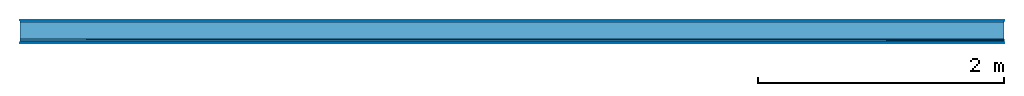
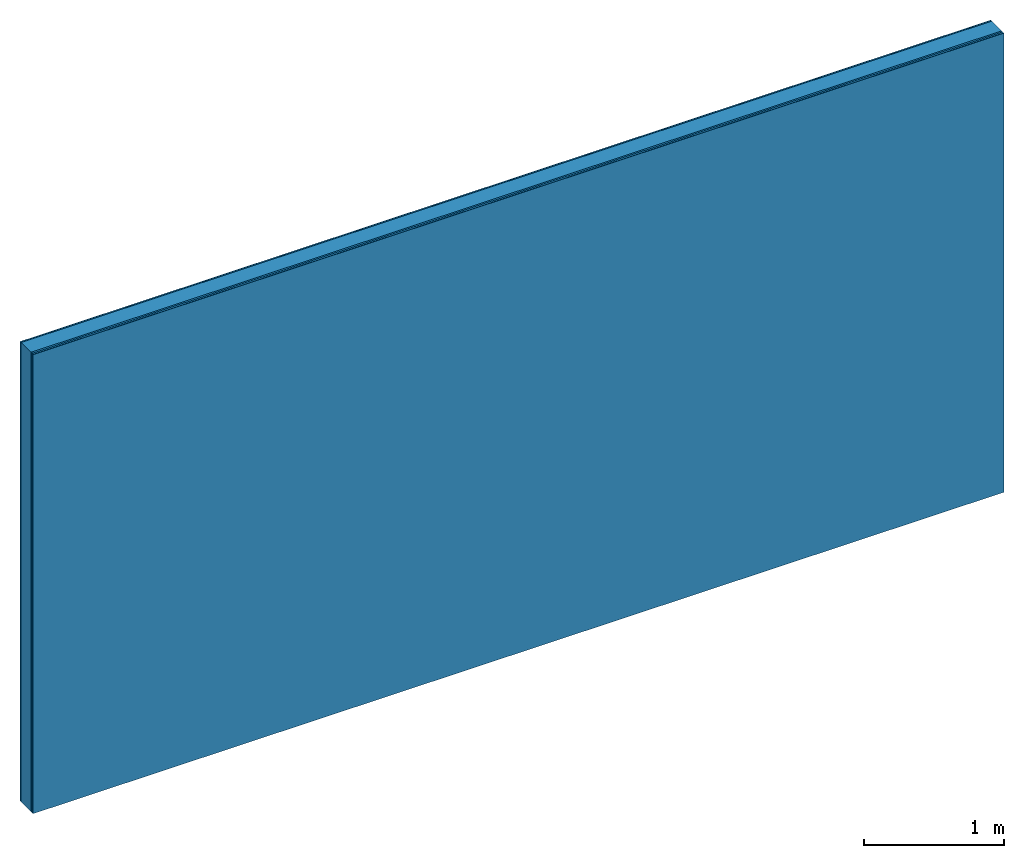
# One storey: 5 plates, 1 member, 1 element without a shape of its own.
"""IFC4 building model written with IfcOpenShell, lengths in metres."""

from ifc_helpers import new_model, si_unit, derived_unit, direction, frame, frame_2d, origin, origin_with_axes, place, context, project, spatial, rectangle, extrude, material, layer, layer_set, type_object, element, aggregate, save


model = new_model("IFC4")

# Units and contexts
plan_context = context("Plan", 3, precision=1e-05, world=origin(), true_north=direction((0.0, 1.0)))
model_context = context("Model", 3, precision=1e-05, world=origin(), true_north=direction((0.0, 1.0)))
ifc_project = project(units=[si_unit("LENGTHUNIT", "METRE"), derived_unit("SOUNDPRESSUREUNIT", [(si_unit("PRESSUREUNIT", "PASCAL", prefix="MICRO"), 0)]), si_unit("ENERGYUNIT", "JOULE", prefix="MEGA"), si_unit("MASSUNIT", "GRAM", prefix="KILO"), derived_unit("THERMALTRANSMITTANCEUNIT", [(si_unit("POWERUNIT", "WATT"), 1), (si_unit("AREAUNIT", "SQUARE_METRE"), -1), (si_unit("THERMODYNAMICTEMPERATUREUNIT", "KELVIN"), -1)]), derived_unit("AREADENSITYUNIT", [(si_unit("MASSUNIT", "GRAM", prefix="KILO"), 1), (si_unit("AREAUNIT", "SQUARE_METRE"), -1)]), derived_unit("USERDEFINED", [(si_unit("ENERGYUNIT", "JOULE", prefix="MEGA"), 1), (si_unit("AREAUNIT", "SQUARE_METRE"), -1)])], contexts=[plan_context, model_context])

# Site, building, storey
site = spatial("IfcSite", under=ifc_project)
building_placement = place(None, origin())
building = spatial("IfcBuilding", under=site, at=building_placement)
storey_placement = place(building_placement, origin())
storey = spatial("IfcBuildingStorey", under=building, at=storey_placement)

# Wall, member, plates
ifc_material_1 = material(Category="04.001")
ifc_layer_1 = layer(ifc_material_1, 0.003, Name="Surface")
ifc_material_2 = material(Name="Plasterboard type A", Category="03.008")
ifc_layer_2 = layer(ifc_material_2, 0.0125, Name="1st layer")
ifc_material_3 = material(Name="of the art")
ifc_layer_3 = layer(ifc_material_3, 0.0, Name="Bond")
ifc_layer_4 = layer(None, 0.14, Name="Support")
ifc_layer_5 = layer(ifc_material_3, 0.0, Name="Bond")
ifc_material_4 = material(Name="DFH2IR Knauf Diamant hard- plasterboard", Category="03.007")
ifc_layer_6 = layer(ifc_material_4, 0.015, Name="1st layer")
ifc_layer_7 = layer(ifc_material_4, 0.015, Name="2nd layer")
ifc_layer_8 = layer(ifc_material_1, 0.003, Name="Surface")
ifc_layer_set = layer_set([ifc_layer_1, ifc_layer_2, ifc_layer_3, ifc_layer_4, ifc_layer_5, ifc_layer_6, ifc_layer_7, ifc_layer_8])
wall_type = type_object("IfcWallType", Name="C0370", PredefinedType="NOTDEFINED", material=ifc_layer_set)
wall_placement = place(None, frame((0.0, 0.0, 0.0), z_axis=(0.0, -1.0, 0.0), x_axis=(1.0, 0.0, 0.0)))
wall = element("IfcWall", 1, at=wall_placement, inside=storey, type_object=wall_type, material=ifc_layer_set, Name="Wall #1")
ifc_material_5 = material(Name="Solid timber panel")
member_placement = place(wall_placement, origin())
member = element("IfcMember", 2, at=member_placement, material=ifc_material_5, Name="Support", context=plan_context, shape_type="SweptSolid", body=[
    extrude(rectangle(XDim=1.0, YDim=0.14, at=frame_2d((0.5, 0.07), x_axis=(1.0, 0.0))), frame((0.0, 4.0, 0.0155), z_axis=(0.0, -1.0, 0.0), x_axis=(1.0, 0.0, 0.0)), (0.0, 0.0, 1.0), 4.0),
    extrude(rectangle(XDim=1.0, YDim=0.14, at=frame_2d((0.5, 0.07), x_axis=(1.0, 0.0))), frame((1.0, 4.0, 0.0155), z_axis=(0.0, -1.0, 0.0), x_axis=(1.0, 0.0, 0.0)), (0.0, 0.0, 1.0), 4.0),
    extrude(rectangle(XDim=1.0, YDim=0.14, at=frame_2d((0.5, 0.07), x_axis=(1.0, 0.0))), frame((2.0, 4.0, 0.0155), z_axis=(0.0, -1.0, 0.0), x_axis=(1.0, 0.0, 0.0)), (0.0, 0.0, 1.0), 4.0),
    extrude(rectangle(XDim=1.0, YDim=0.14, at=frame_2d((0.5, 0.07), x_axis=(1.0, 0.0))), frame((3.0, 4.0, 0.0155), z_axis=(0.0, -1.0, 0.0), x_axis=(1.0, 0.0, 0.0)), (0.0, 0.0, 1.0), 4.0),
    extrude(rectangle(XDim=1.0, YDim=0.14, at=frame_2d((0.5, 0.07), x_axis=(1.0, 0.0))), frame((4.0, 4.0, 0.0155), z_axis=(0.0, -1.0, 0.0), x_axis=(1.0, 0.0, 0.0)), (0.0, 0.0, 1.0), 4.0),
    extrude(rectangle(XDim=1.0, YDim=0.14, at=frame_2d((0.5, 0.07), x_axis=(1.0, 0.0))), frame((5.0, 4.0, 0.0155), z_axis=(0.0, -1.0, 0.0), x_axis=(1.0, 0.0, 0.0)), (0.0, 0.0, 1.0), 4.0),
    extrude(rectangle(XDim=1.0, YDim=0.14, at=frame_2d((0.5, 0.07), x_axis=(1.0, 0.0))), frame((6.0, 4.0, 0.0155), z_axis=(0.0, -1.0, 0.0), x_axis=(1.0, 0.0, 0.0)), (0.0, 0.0, 1.0), 4.0),
    extrude(rectangle(XDim=1.0, YDim=0.14, at=frame_2d((0.5, 0.07), x_axis=(1.0, 0.0))), frame((7.0, 4.0, 0.0155), z_axis=(0.0, -1.0, 0.0), x_axis=(1.0, 0.0, 0.0)), (0.0, 0.0, 1.0), 4.0),
])
plate_1_placement = place(wall_placement, origin())
plate_1 = element("IfcPlate", 3, at=plate_1_placement, material=ifc_material_1, Name="Surface", context=plan_context, shape_type="SweptSolid", body=[
    extrude(rectangle(XDim=8.0, YDim=4.0, at=frame_2d((4.0, 2.0), x_axis=(1.0, 0.0))), origin_with_axes(), (0.0, 0.0, 1.0), 0.003),
])
plate_2_placement = place(wall_placement, origin())
plate_2 = element("IfcPlate", 4, at=plate_2_placement, material=ifc_material_2, Name="1st layer", context=plan_context, shape_type="SweptSolid", body=[
    extrude(rectangle(XDim=8.0, YDim=4.0, at=frame_2d((4.0, 2.0), x_axis=(1.0, 0.0))), frame((0.0, 0.0, 0.003), z_axis=(0.0, 0.0, 1.0), x_axis=(1.0, 0.0, 0.0)), (0.0, 0.0, 1.0), 0.0125),
])
plate_3_placement = place(wall_placement, origin())
plate_3 = element("IfcPlate", 5, at=plate_3_placement, material=ifc_material_4, Name="1st layer", context=plan_context, shape_type="SweptSolid", body=[
    extrude(rectangle(XDim=8.0, YDim=4.0, at=frame_2d((4.0, 2.0), x_axis=(1.0, 0.0))), frame((0.0, 0.0, 0.1555), z_axis=(0.0, 0.0, 1.0), x_axis=(1.0, 0.0, 0.0)), (0.0, 0.0, 1.0), 0.015),
])
plate_4_placement = place(wall_placement, origin())
plate_4 = element("IfcPlate", 6, at=plate_4_placement, material=ifc_material_4, Name="2nd layer", context=plan_context, shape_type="SweptSolid", body=[
    extrude(rectangle(XDim=8.0, YDim=4.0, at=frame_2d((4.0, 2.0), x_axis=(1.0, 0.0))), frame((0.0, 0.0, 0.1705), z_axis=(0.0, 0.0, 1.0), x_axis=(1.0, 0.0, 0.0)), (0.0, 0.0, 1.0), 0.015),
])
plate_5_placement = place(wall_placement, origin())
plate_5 = element("IfcPlate", 7, at=plate_5_placement, material=ifc_material_1, Name="Surface", context=plan_context, shape_type="SweptSolid", body=[
    extrude(rectangle(XDim=8.0, YDim=4.0, at=frame_2d((4.0, 2.0), x_axis=(1.0, 0.0))), frame((0.0, 0.0, 0.1855), z_axis=(0.0, 0.0, 1.0), x_axis=(1.0, 0.0, 0.0)), (0.0, 0.0, 1.0), 0.003),
])
aggregate(wall, [plate_1, plate_2, member, plate_3, plate_4, plate_5])

save(model, "model.ifc")
